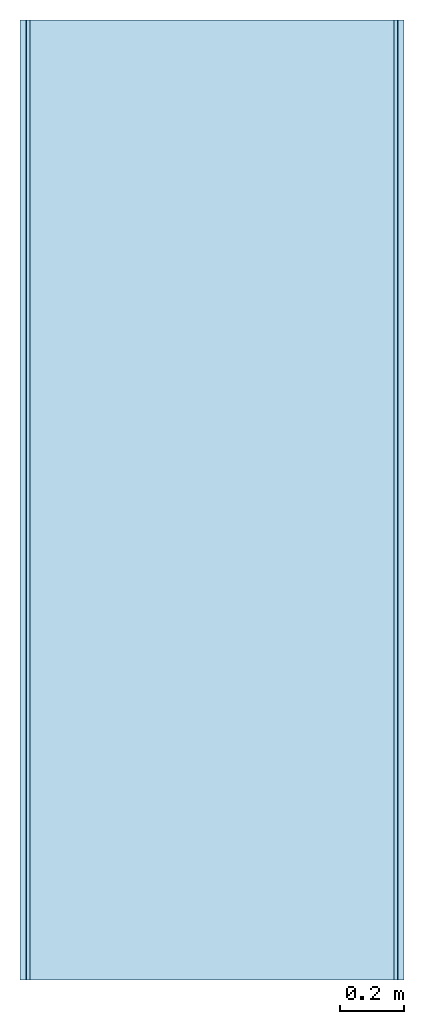
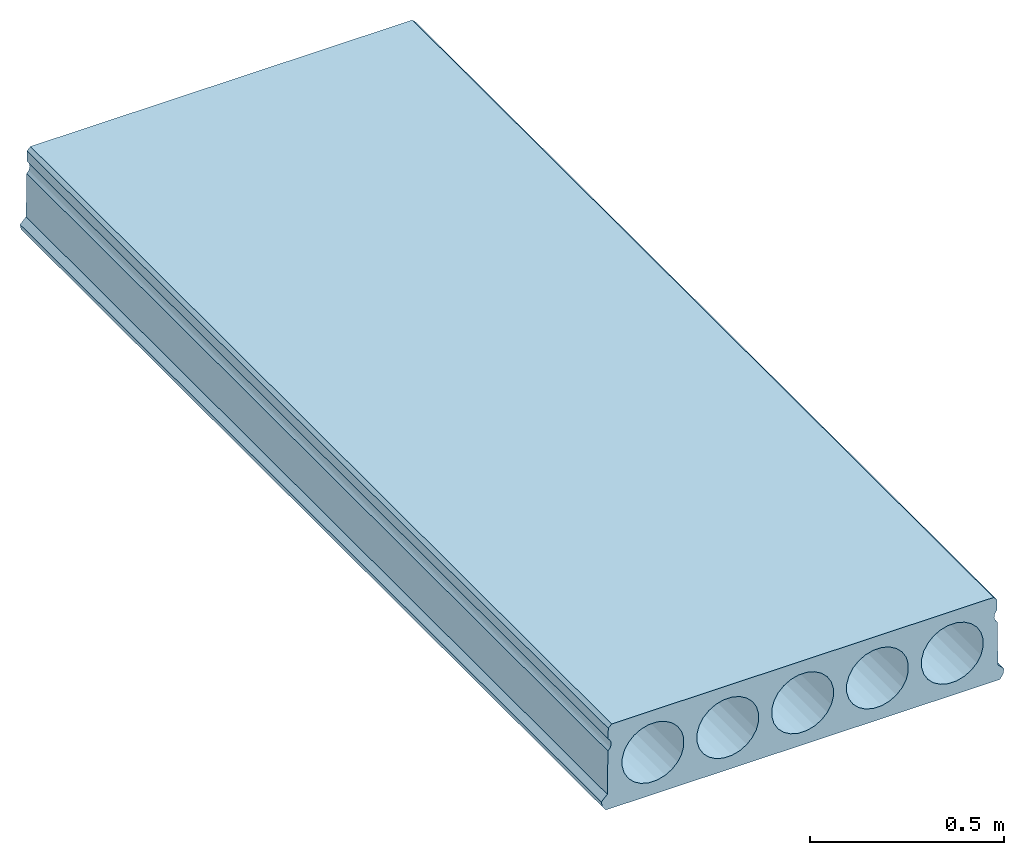
# One storey: 1 slab.
"""IFC4 building model written with IfcOpenShell, lengths in millimetres."""

from ifc_helpers import new_model, entity, si_unit, converted_unit, frame, origin_with_axes, origin_2d_with_axis, place, context, subcontext, project, spatial, indexed_curve, outline, extrude, material, material_profile, profile_set, profile_usage, type_object, element, save


model = new_model("IFC4")

# Units and contexts
model_context = context("Model", 3, precision=1e-05, world=origin_with_axes())
plan_context = context("Plan", 2, precision=1e-05, world=origin_2d_with_axis())
body_context = subcontext(model_context, "Body", "Model", "MODEL_VIEW")
ifc_project = project(units=[si_unit("VOLUMEUNIT", "CUBIC_METRE"), si_unit("LENGTHUNIT", "METRE", prefix="MILLI"), converted_unit("PLANEANGLEUNIT", "degree", entity("IfcReal", 0.0174532925199433), si_unit("PLANEANGLEUNIT", "RADIAN"), dimensions=[0, 0, 0, 0, 0, 0, 0]), si_unit("AREAUNIT", "SQUARE_METRE")], contexts=[model_context, plan_context])

# Site, building, storey
site_placement = place(None, origin_with_axes())
site = spatial("IfcSite", under=ifc_project, at=site_placement)
building_placement = place(site_placement, origin_with_axes())
building = spatial("IfcBuilding", under=site, at=building_placement, Name="Building")
storey_placement = place(building_placement, origin_with_axes())
storey = spatial("IfcBuildingStorey", under=building, at=storey_placement, Name="Storey")

# Slab
ifc_material = material()
ifc_material_profile = material_profile(ifc_material, outline(indexed_curve([(581.327331542969, 47.9965133666992), (579.36572265625, 183.999984741211), (573.913452148438, 190.100646972656), (571.218872070312, 195.967651367188), (570.160278320312, 202.189895629883), (570.708251953125, 208.436935424805), (572.83447265625, 214.379287719727), (576.509460449219, 219.687438964844), (578.918823242188, 222.000564575195), (578.462097167969, 255.001022338867), (568.323547363281, 265.000335693359), (-569.676391601562, 265.000335693359), (-579.814331054688, 255.001022338867), (-580.271606445312, 222.000564575195), (-574.883361816406, 215.654342651367), (-572.367553710938, 209.727737426758), (-571.492553710938, 203.494995117188), (-572.22021484375, 197.283233642578), (-574.511901855469, 191.421478271484), (-578.328979492188, 186.236831665039), (-580.797607421875, 184.000946044922), (-582.675354003906, 48.0012817382812), (-600.675476074219, 30.0002059936523), (-597.675231933594, 14.0004138946533), (-587.675476074219, 0.0), (587.675476074219, 0.0), (597.322814941406, 16.0031299591064), (599.323181152344, 30.0011596679688), (581.327331542969, 47.9965133666992)]), holes=[indexed_curve([(-519.897399902344, 75.9816055297852), (-503.193359375, 59.2775268554688), (-482.674072265625, 47.2707672119141), (-459.224151611328, 40.8444328308105), (-434.126800537109, 40.8449096679688), (-410.676422119141, 47.2717208862305), (-390.157165527344, 59.2784805297852), (-373.453552246094, 75.9830322265625), (-361.446807861328, 96.501335144043), (-355.019989013672, 119.952186584473), (-355.020935058594, 145.049545288086), (-361.447326660156, 168.499923706055), (-373.454040527344, 189.018707275391), (-390.158111572266, 205.722778320312), (-410.676422119141, 217.729537963867), (-434.127319335938, 224.156356811523), (-459.225128173828, 224.154449462891), (-482.675018310547, 217.728591918945), (-503.194305419922, 205.721832275391), (-519.898315429688, 189.018218994141), (-531.904602050781, 168.498962402344), (-538.331481933594, 145.048110961914), (-538.330444335938, 119.95027923584), (-531.904113769531, 96.5003814697266), (-519.897399902344, 75.9816055297852)]), indexed_curve([(-36.674015045166, 47.2707672119141), (-57.1932716369629, 59.2775268554688), (-73.897346496582, 75.9816055297852), (-85.9041061401367, 96.5003814697266), (-92.3304443359375, 119.95027923584), (-92.3313980102539, 145.048110961914), (-85.9045867919922, 168.498962402344), (-73.8978271484375, 189.018218994141), (-57.1942253112793, 205.721832275391), (-36.6754455566406, 217.728591918945), (-13.225076675415, 224.154922485352), (11.872766494751, 224.155868530273), (35.3236122131348, 217.729537963867), (55.8419151306152, 205.722778320312), (72.5464706420898, 189.018707275391), (84.5527496337891, 168.499923706055), (90.9790878295898, 145.049545288086), (90.9800415039062, 119.952186584473), (84.5532302856445, 96.501335144043), (72.5464706420898, 75.9830322265625), (55.8428688049316, 59.2784805297852), (35.3236122131348, 47.2717208862305), (11.8732433319092, 40.8449096679688), (-13.2241230010986, 40.8444328308105), (-36.674015045166, 47.2707672119141)]), indexed_curve([(457.871368408203, 224.155868530273), (432.773529052734, 224.154922485352), (409.323150634766, 217.728591918945), (388.804901123047, 205.721832275391), (372.100341796875, 189.018218994141), (360.093536376953, 168.498962402344), (353.667724609375, 145.048110961914), (353.667724609375, 119.95027923584), (360.094482421875, 96.5003814697266), (372.100769042969, 75.9816055297852), (388.804901123047, 59.2775268554688), (409.324157714844, 47.2707672119141), (432.774017333984, 40.8444328308105), (457.871856689453, 40.8449096679688), (481.322692871094, 47.2717208862305), (501.840972900391, 59.2784805297852), (518.545532226562, 75.9830322265625), (530.552368164062, 96.501335144043), (536.978149414062, 119.952186584473), (536.977172851562, 145.049545288086), (530.551330566406, 168.499923706055), (518.544189453125, 189.018707275391), (501.840087890625, 205.722778320312), (481.3212890625, 217.729537963867), (457.871368408203, 224.155868530273)]), indexed_curve([(-280.193756103516, 205.721832275391), (-296.898315429688, 189.018218994141), (-308.905120849609, 168.498962402344), (-315.331451416016, 145.048110961914), (-315.330017089844, 119.95027923584), (-308.904113769531, 96.5003814697266), (-296.897399902344, 75.9816055297852), (-280.193267822266, 59.2775268554688), (-259.674499511719, 47.2707672119141), (-236.223663330078, 40.8444328308105), (-211.126770019531, 40.8449096679688), (-187.675933837891, 47.2717208862305), (-167.157623291016, 59.2784805297852), (-150.453063964844, 75.9830322265625), (-138.446304321289, 96.501335144043), (-132.020446777344, 119.952186584473), (-132.020446777344, 145.049545288086), (-138.447280883789, 168.499923706055), (-150.454040527344, 189.018707275391), (-167.158096313477, 205.722778320312), (-187.676879882812, 217.729537963867), (-211.126770019531, 224.156356811523), (-236.224624633789, 224.154449462891), (-259.675445556641, 217.728591918945), (-280.193756103516, 205.721832275391)]), indexed_curve([(295.544097900391, 189.018707275391), (278.840484619141, 205.722778320312), (258.321228027344, 217.729537963867), (234.871353149414, 224.155868530273), (209.773513793945, 224.154922485352), (186.323135375977, 217.728591918945), (165.804382324219, 205.721832275391), (149.100280761719, 189.018218994141), (137.093994140625, 168.498962402344), (130.667205810547, 145.048110961914), (130.667663574219, 119.95027923584), (137.093994140625, 96.5003814697266), (149.10075378418, 75.9816055297852), (165.805313110352, 59.2775268554688), (186.323638916016, 47.2707672119141), (209.774459838867, 40.8444328308105), (234.872314453125, 40.8449096679688), (258.322235107422, 47.2717208862305), (278.841491699219, 59.2784805297852), (295.545532226562, 75.9830322265625), (307.551849365234, 96.501335144043), (313.978149414062, 119.952186584473), (313.977661132812, 145.049545288086), (307.550903320312, 168.499923706055), (295.544097900391, 189.018707275391)])]))
ifc_profile_set = profile_set([ifc_material_profile])
ifc_profile_usage = profile_usage(ifc_profile_set, cardinal=5)
slab_type = type_object("IfcSlabType", PredefinedType="FLOOR", material=ifc_profile_set)
slab_placement = place(storey_placement, frame((0.0, 0.0, 0.0), z_axis=(-4.37113873394258e-08, -0.999999999999996, 7.54978986586411e-08), x_axis=(0.999999999999999, -4.37113882867379e-08, 0.0)))
element("IfcSlab", 1, at=slab_placement, inside=storey, type_object=slab_type, material=ifc_profile_usage, Name="Slab", context=body_context, shape_type="SweptSolid", body=[
    extrude(outline(indexed_curve([(581.327331542969, 47.9965133666992), (579.36572265625, 183.999984741211), (573.913452148438, 190.100646972656), (571.218872070312, 195.967651367188), (570.160278320312, 202.189895629883), (570.708251953125, 208.436935424805), (572.83447265625, 214.379287719727), (576.509460449219, 219.687438964844), (578.918823242188, 222.000564575195), (578.462097167969, 255.001022338867), (568.323547363281, 265.000335693359), (-569.676391601562, 265.000335693359), (-579.814331054688, 255.001022338867), (-580.271606445312, 222.000564575195), (-574.883361816406, 215.654342651367), (-572.367553710938, 209.727737426758), (-571.492553710938, 203.494995117188), (-572.22021484375, 197.283233642578), (-574.511901855469, 191.421478271484), (-578.328979492188, 186.236831665039), (-580.797607421875, 184.000946044922), (-582.675354003906, 48.0012817382812), (-600.675476074219, 30.0002059936523), (-597.675231933594, 14.0004138946533), (-587.675476074219, 0.0), (587.675476074219, 0.0), (597.322814941406, 16.0031299591064), (599.323181152344, 30.0011596679688), (581.327331542969, 47.9965133666992)]), holes=[indexed_curve([(-519.897399902344, 75.9816055297852), (-503.193359375, 59.2775268554688), (-482.674072265625, 47.2707672119141), (-459.224151611328, 40.8444328308105), (-434.126800537109, 40.8449096679688), (-410.676422119141, 47.2717208862305), (-390.157165527344, 59.2784805297852), (-373.453552246094, 75.9830322265625), (-361.446807861328, 96.501335144043), (-355.019989013672, 119.952186584473), (-355.020935058594, 145.049545288086), (-361.447326660156, 168.499923706055), (-373.454040527344, 189.018707275391), (-390.158111572266, 205.722778320312), (-410.676422119141, 217.729537963867), (-434.127319335938, 224.156356811523), (-459.225128173828, 224.154449462891), (-482.675018310547, 217.728591918945), (-503.194305419922, 205.721832275391), (-519.898315429688, 189.018218994141), (-531.904602050781, 168.498962402344), (-538.331481933594, 145.048110961914), (-538.330444335938, 119.95027923584), (-531.904113769531, 96.5003814697266), (-519.897399902344, 75.9816055297852)]), indexed_curve([(-36.674015045166, 47.2707672119141), (-57.1932716369629, 59.2775268554688), (-73.897346496582, 75.9816055297852), (-85.9041061401367, 96.5003814697266), (-92.3304443359375, 119.95027923584), (-92.3313980102539, 145.048110961914), (-85.9045867919922, 168.498962402344), (-73.8978271484375, 189.018218994141), (-57.1942253112793, 205.721832275391), (-36.6754455566406, 217.728591918945), (-13.225076675415, 224.154922485352), (11.872766494751, 224.155868530273), (35.3236122131348, 217.729537963867), (55.8419151306152, 205.722778320312), (72.5464706420898, 189.018707275391), (84.5527496337891, 168.499923706055), (90.9790878295898, 145.049545288086), (90.9800415039062, 119.952186584473), (84.5532302856445, 96.501335144043), (72.5464706420898, 75.9830322265625), (55.8428688049316, 59.2784805297852), (35.3236122131348, 47.2717208862305), (11.8732433319092, 40.8449096679688), (-13.2241230010986, 40.8444328308105), (-36.674015045166, 47.2707672119141)]), indexed_curve([(457.871368408203, 224.155868530273), (432.773529052734, 224.154922485352), (409.323150634766, 217.728591918945), (388.804901123047, 205.721832275391), (372.100341796875, 189.018218994141), (360.093536376953, 168.498962402344), (353.667724609375, 145.048110961914), (353.667724609375, 119.95027923584), (360.094482421875, 96.5003814697266), (372.100769042969, 75.9816055297852), (388.804901123047, 59.2775268554688), (409.324157714844, 47.2707672119141), (432.774017333984, 40.8444328308105), (457.871856689453, 40.8449096679688), (481.322692871094, 47.2717208862305), (501.840972900391, 59.2784805297852), (518.545532226562, 75.9830322265625), (530.552368164062, 96.501335144043), (536.978149414062, 119.952186584473), (536.977172851562, 145.049545288086), (530.551330566406, 168.499923706055), (518.544189453125, 189.018707275391), (501.840087890625, 205.722778320312), (481.3212890625, 217.729537963867), (457.871368408203, 224.155868530273)]), indexed_curve([(-280.193756103516, 205.721832275391), (-296.898315429688, 189.018218994141), (-308.905120849609, 168.498962402344), (-315.331451416016, 145.048110961914), (-315.330017089844, 119.95027923584), (-308.904113769531, 96.5003814697266), (-296.897399902344, 75.9816055297852), (-280.193267822266, 59.2775268554688), (-259.674499511719, 47.2707672119141), (-236.223663330078, 40.8444328308105), (-211.126770019531, 40.8449096679688), (-187.675933837891, 47.2717208862305), (-167.157623291016, 59.2784805297852), (-150.453063964844, 75.9830322265625), (-138.446304321289, 96.501335144043), (-132.020446777344, 119.952186584473), (-132.020446777344, 145.049545288086), (-138.447280883789, 168.499923706055), (-150.454040527344, 189.018707275391), (-167.158096313477, 205.722778320312), (-187.676879882812, 217.729537963867), (-211.126770019531, 224.156356811523), (-236.224624633789, 224.154449462891), (-259.675445556641, 217.728591918945), (-280.193756103516, 205.721832275391)]), indexed_curve([(295.544097900391, 189.018707275391), (278.840484619141, 205.722778320312), (258.321228027344, 217.729537963867), (234.871353149414, 224.155868530273), (209.773513793945, 224.154922485352), (186.323135375977, 217.728591918945), (165.804382324219, 205.721832275391), (149.100280761719, 189.018218994141), (137.093994140625, 168.498962402344), (130.667205810547, 145.048110961914), (130.667663574219, 119.95027923584), (137.093994140625, 96.5003814697266), (149.10075378418, 75.9816055297852), (165.805313110352, 59.2775268554688), (186.323638916016, 47.2707672119141), (209.774459838867, 40.8444328308105), (234.872314453125, 40.8449096679688), (258.322235107422, 47.2717208862305), (278.841491699219, 59.2784805297852), (295.545532226562, 75.9830322265625), (307.551849365234, 96.501335144043), (313.978149414062, 119.952186584473), (313.977661132812, 145.049545288086), (307.550903320312, 168.499923706055), (295.544097900391, 189.018707275391)])]), origin_with_axes(), (0.0, 0.0, 1.0), 2999.99952316282),
])

save(model, "model.ifc")
